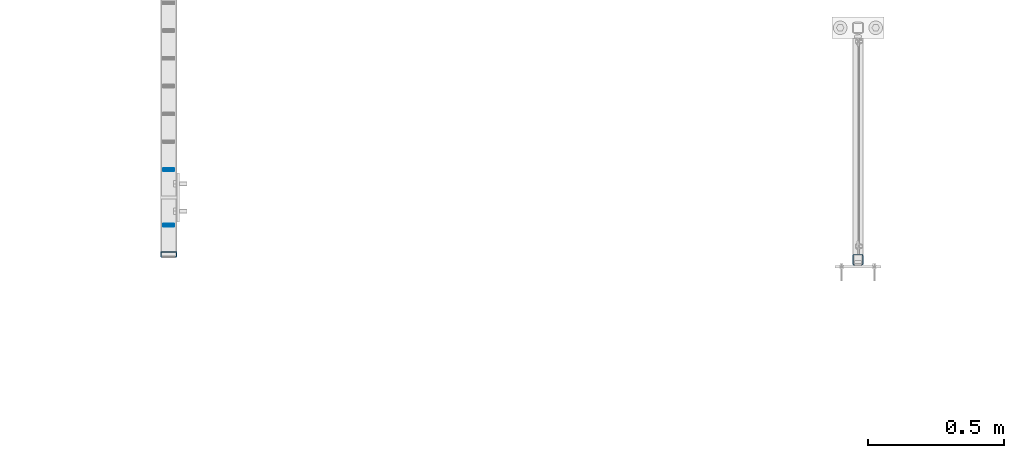
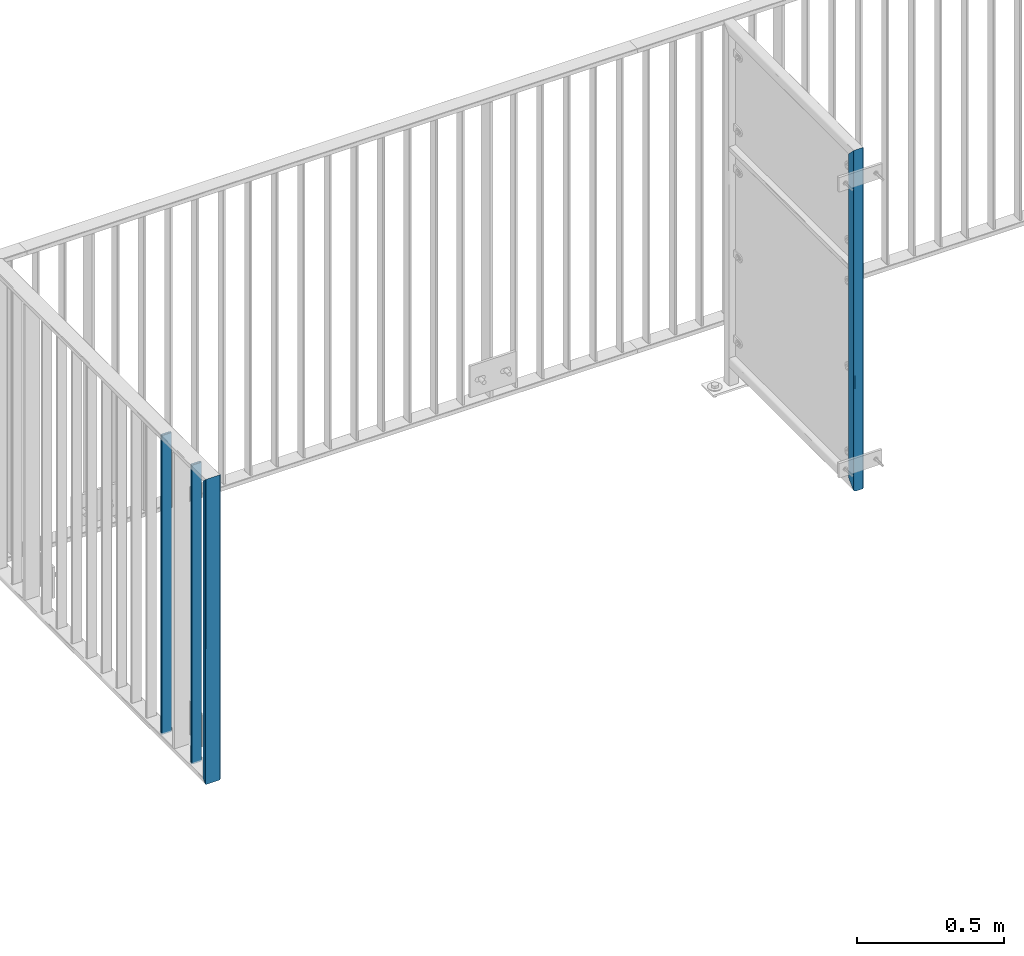
# One storey, part 32 of 156: 4 beams, 2 elements without a shape of their own.
"""IFC2X3 building model written with IfcOpenShell, lengths in millimetres."""

from ifc_helpers import new_model, si_unit, frame, origin_with_axes, origin_2d_with_axis, place, context, subcontext, project, spatial, hollow_rectangle, extrude, clip, halfspace, material, type_object, element, aggregate, save


model = new_model("IFC2X3")

# Units and contexts
model_context = context("Model", 3, precision=1e-05, world=origin_with_axes())
body_context = subcontext(model_context, "Body", "Model", "MODEL_VIEW")
ifc_project = project(units=[si_unit("LENGTHUNIT", "METRE", prefix="MILLI"), si_unit("AREAUNIT", "SQUARE_METRE"), si_unit("VOLUMEUNIT", "CUBIC_METRE"), si_unit("MASSUNIT", "GRAM", prefix="KILO"), si_unit("TIMEUNIT", "SECOND"), si_unit("PLANEANGLEUNIT", "RADIAN"), si_unit("SOLIDANGLEUNIT", "STERADIAN"), si_unit("THERMODYNAMICTEMPERATUREUNIT", "DEGREE_CELSIUS"), si_unit("LUMINOUSINTENSITYUNIT", "LUMEN")], contexts=[model_context])

# Site, building, storey
site_placement = place(None, origin_with_axes())
site = spatial("IfcSite", under=ifc_project, at=site_placement, CompositionType="ELEMENT")
building_placement = place(site_placement, origin_with_axes())
building = spatial("IfcBuilding", under=site, at=building_placement, Name="Undefined", CompositionType="ELEMENT")
storey_placement = place(building_placement, origin_with_axes())
storey = spatial("IfcBuildingStorey", under=building, at=storey_placement, Name="Undefined", CompositionType="ELEMENT", Elevation=0.0)

# Assembly, beams
assembly_1_placement = place(storey_placement, origin_with_axes())
assembly_1 = element("IfcElementAssembly", 1, at=assembly_1_placement, inside=storey, AssemblyPlace="NOTDEFINED", PredefinedType="RIGID_FRAME")
ifc_material = material(Name="STEEL/S235JR")
beam_type_1 = type_object("IfcBeamType", Name="K60/20/2", PredefinedType="NOTDEFINED")
beam_1_placement = place(assembly_1_placement, frame((41074.9995269775, 20158.0001005923, 4000.0), z_axis=(1.0, 0.0, 0.0), x_axis=(0.0, 0.0, -1.0)))
beam_1 = element("IfcBeam", 2, at=beam_1_placement, type_object=beam_type_1, material=ifc_material, ObjectType="K60/20/2", context=body_context, shape_type="Clipping", body=[
    clip(clip(extrude(hollow_rectangle(XDim=20.0, YDim=60.0, WallThickness=2.0, InnerFilletRadius=2.0, OuterFilletRadius=4.0, at=origin_2d_with_axis()), frame((1280.2, 0.0, 0.0), z_axis=(-1.0, 0.0, 0.0), x_axis=(0.0, -1.0, 0.0)), (0.0, 0.0, 1.0), 1290.4), halfspace(frame((1270.0, -10.0, 0.0), z_axis=(0.707106781186548, 0.707106781186548, 0.0), x_axis=(0.0, 0.0, 1.0)), False)), halfspace(frame((20.0, 10.0, 0.0), z_axis=(-0.707106781186548, 0.707106781186548, 0.0), x_axis=(0.0, 0.0, 1.0)), False)),
])
beam_type_2 = type_object("IfcBeamType", Name="K40/10/1.5", PredefinedType="NOTDEFINED")
beam_2_placement = place(assembly_1_placement, frame((41074.9973679284, 20264.8492182564, 3980.00000000003), z_axis=(1.0, 0.0, 0.0), x_axis=(0.0, 0.0, -1.0)))
beam_2 = element("IfcBeam", 3, at=beam_2_placement, type_object=beam_type_2, material=ifc_material, ObjectType="K40/10/1.5", context=body_context, shape_type="Clipping", body=[
    clip(clip(extrude(hollow_rectangle(XDim=10.0, YDim=40.0, WallThickness=1.5, InnerFilletRadius=1.5, OuterFilletRadius=3.0, at=origin_2d_with_axis()), frame((1237.00000000003, 0.0, 0.0), z_axis=(-1.0, 0.0, 0.0), x_axis=(0.0, -1.0, 0.0)), (0.0, 0.0, 1.0), 1244.0), halfspace(frame((1237.00000000003, 3.2449841921989, 46.4665039507236), z_axis=(1.0, 0.0, 0.0), x_axis=(0.0, -0.754414263122933, -0.656398598106883)), False)), halfspace(frame((-6.99999999997453, -3.24498419219526, 46.4665039507308), z_axis=(-1.0, 0.0, 0.0), x_axis=(0.0, 0.75441426312288, -0.656398598106944)), False)),
])
beam_3_placement = place(assembly_1_placement, frame((41074.9973679284, 20468.4092182564, 3980.00000000003), z_axis=(1.0, 0.0, 0.0), x_axis=(0.0, 0.0, -1.0)))
beam_3 = element("IfcBeam", 4, at=beam_3_placement, type_object=beam_type_2, material=ifc_material, ObjectType="K40/10/1.5", context=body_context, shape_type="Clipping", body=[
    clip(clip(extrude(hollow_rectangle(XDim=10.0, YDim=40.0, WallThickness=1.5, InnerFilletRadius=1.5, OuterFilletRadius=3.0, at=origin_2d_with_axis()), frame((1237.00000000003, 0.0, 0.0), z_axis=(-1.0, 0.0, 0.0), x_axis=(0.0, -1.0, 0.0)), (0.0, 0.0, 1.0), 1244.0), halfspace(frame((1237.00000000003, 3.2449841921989, 46.4665039507236), z_axis=(1.0, 0.0, 0.0), x_axis=(0.0, -0.754414263122933, -0.656398598106883)), False)), halfspace(frame((-6.99999999997453, -3.24498419219526, 46.4665039507308), z_axis=(-1.0, 0.0, 0.0), x_axis=(0.0, 0.75441426312288, -0.656398598106944)), False)),
])
aggregate(assembly_1, [beam_2, beam_3, beam_1])

# Assembly, beam
assembly_2_placement = place(storey_placement, origin_with_axes())
assembly_2 = element("IfcElementAssembly", 5, at=assembly_2_placement, inside=storey, AssemblyPlace="NOTDEFINED", PredefinedType="RIGID_FRAME")
beam_type_3 = type_object("IfcBeamType", Name="K40/3", PredefinedType="NOTDEFINED")
beam_4_placement = place(assembly_2_placement, frame((43599.9990081787, 20137.999887596, 4299.9999999525), z_axis=(1.0, 0.0, 0.0), x_axis=(0.0, 0.0, -1.0)))
beam_4 = element("IfcBeam", 6, at=beam_4_placement, type_object=beam_type_3, material=ifc_material, ObjectType="K40/3", context=body_context, shape_type="Clipping", body=[
    clip(clip(extrude(hollow_rectangle(XDim=40.0, YDim=40.0, WallThickness=3.0, InnerFilletRadius=3.0, OuterFilletRadius=6.0, at=origin_2d_with_axis()), frame((1240.4, 0.0, 0.0), z_axis=(-1.0, 0.0, 0.0), x_axis=(0.0, -1.0, 0.0)), (0.0, 0.0, 1.0), 1460.8), halfspace(frame((1180.0, 20.0, 0.0), z_axis=(-0.707106781186548, -0.707106781186548, 0.0), x_axis=(0.0, 0.0, 1.0)), True)), halfspace(frame((-200.0, -20.0, 0.0), z_axis=(0.707106781186548, -0.707106781186548, 0.0), x_axis=(0.0, 0.0, 1.0)), True)),
])
aggregate(assembly_2, [beam_4])

save(model, "model.ifc")
